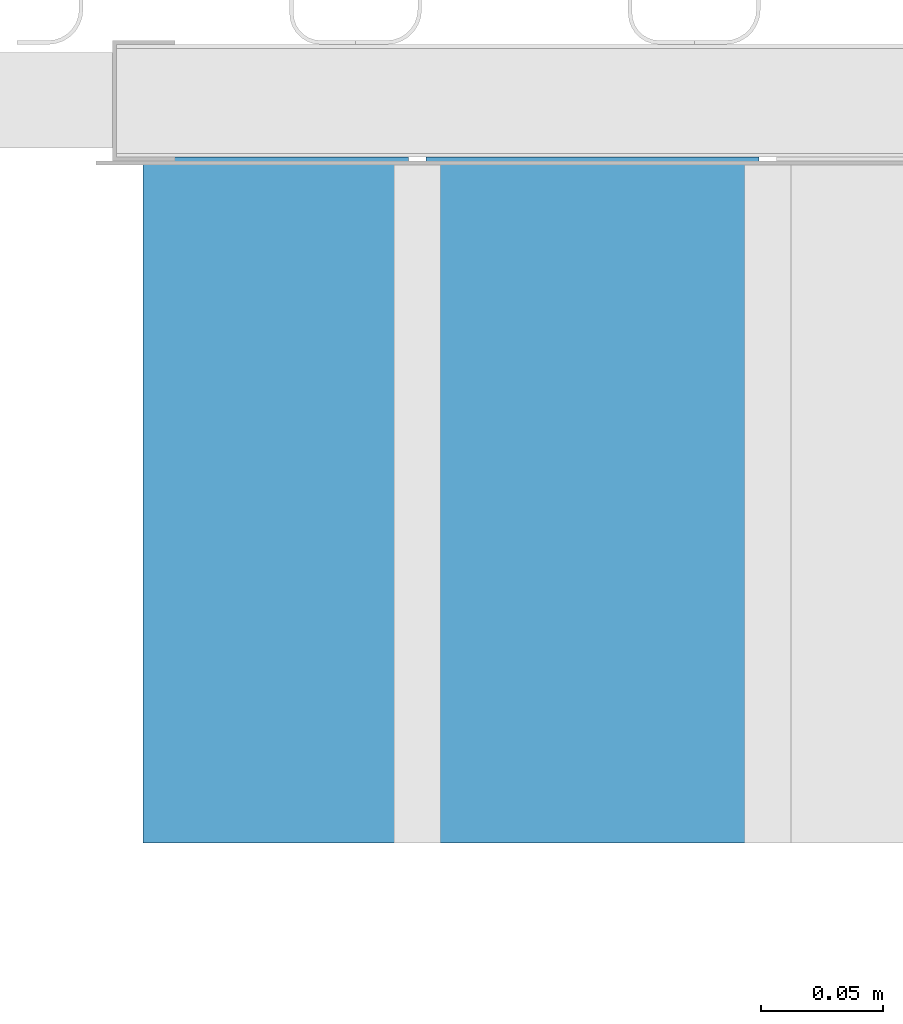
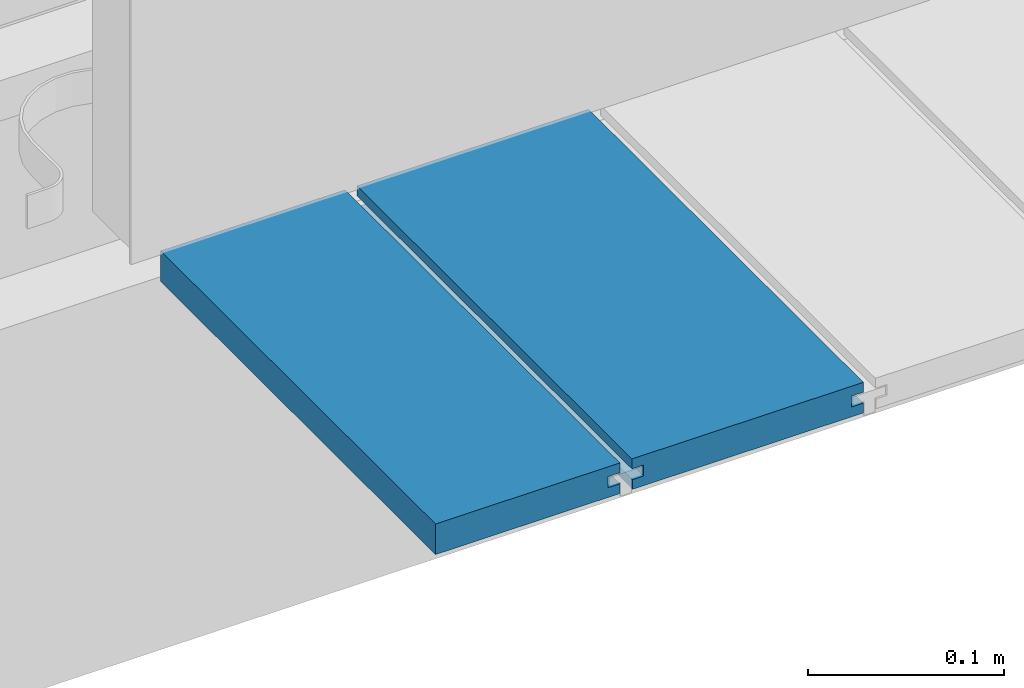
# One storey, part 16 of 33: 2 walls.
"""IFC4 building model written with IfcOpenShell, lengths in feet."""

from ifc_helpers import new_model, entity, si_unit, converted_unit, derived_unit, direction, frame, origin, place, context, subcontext, project, spatial, material, type_object, element, save


model = new_model("IFC4")

# Units and contexts
model_context = context("Model", 3, precision=0.0001, world=origin(), true_north=direction((6.12303176911189e-17, 1.0)))
body_context = subcontext(model_context, "Body", "Model", "MODEL_VIEW")
ifc_project = project(units=[converted_unit("LENGTHUNIT", "FOOT", entity("IfcRatioMeasure", 0.3048), si_unit("LENGTHUNIT", "METRE"), dimensions=[1, 0, 0, 0, 0, 0, 0]), converted_unit("AREAUNIT", "SQUARE FOOT", entity("IfcRatioMeasure", 0.09290304), si_unit("AREAUNIT", "SQUARE_METRE"), dimensions=[2, 0, 0, 0, 0, 0, 0]), converted_unit("VOLUMEUNIT", "CUBIC FOOT", entity("IfcRatioMeasure", 0.028316846592), si_unit("VOLUMEUNIT", "CUBIC_METRE"), dimensions=[3, 0, 0, 0, 0, 0, 0]), converted_unit("PLANEANGLEUNIT", "DEGREE", entity("IfcRatioMeasure", 0.0174532925199433), si_unit("PLANEANGLEUNIT", "RADIAN"), dimensions=[0, 0, 0, 0, 0, 0, 0]), si_unit("MASSUNIT", "GRAM", prefix="KILO"), derived_unit("MASSDENSITYUNIT", [(si_unit("MASSUNIT", "GRAM", prefix="KILO"), 1), (si_unit("LENGTHUNIT", "METRE"), -3)]), derived_unit("MOMENTOFINERTIAUNIT", [(si_unit("LENGTHUNIT", "METRE"), 4)]), si_unit("TIMEUNIT", "SECOND"), si_unit("FREQUENCYUNIT", "HERTZ"), si_unit("THERMODYNAMICTEMPERATUREUNIT", "DEGREE_CELSIUS"), derived_unit("THERMALTRANSMITTANCEUNIT", [(si_unit("MASSUNIT", "GRAM", prefix="KILO"), 1), (si_unit("THERMODYNAMICTEMPERATUREUNIT", "KELVIN"), -1), (si_unit("TIMEUNIT", "SECOND"), -3)]), derived_unit("VOLUMETRICFLOWRATEUNIT", [(si_unit("LENGTHUNIT", "METRE"), 3), (si_unit("TIMEUNIT", "SECOND"), -1)]), si_unit("ELECTRICCURRENTUNIT", "AMPERE"), si_unit("ELECTRICVOLTAGEUNIT", "VOLT"), si_unit("POWERUNIT", "WATT"), si_unit("FORCEUNIT", "NEWTON"), si_unit("ILLUMINANCEUNIT", "LUX"), si_unit("LUMINOUSFLUXUNIT", "LUMEN"), si_unit("LUMINOUSINTENSITYUNIT", "CANDELA"), derived_unit("USERDEFINED", [(si_unit("MASSUNIT", "GRAM", prefix="KILO"), -1), (si_unit("LENGTHUNIT", "METRE"), -2), (si_unit("TIMEUNIT", "SECOND"), 3), (si_unit("LUMINOUSFLUXUNIT", "LUMEN"), 1)]), derived_unit("LINEARVELOCITYUNIT", [(si_unit("LENGTHUNIT", "METRE"), 1), (si_unit("TIMEUNIT", "SECOND"), -1)]), si_unit("PRESSUREUNIT", "PASCAL"), derived_unit("USERDEFINED", [(si_unit("LENGTHUNIT", "METRE"), -2), (si_unit("MASSUNIT", "GRAM", prefix="KILO"), 1), (si_unit("TIMEUNIT", "SECOND"), -2)]), derived_unit("LINEARFORCEUNIT", [(si_unit("MASSUNIT", "GRAM", prefix="KILO"), 1), (si_unit("LENGTHUNIT", "METRE"), 1), (si_unit("TIMEUNIT", "SECOND"), -2), (si_unit("LENGTHUNIT", "METRE"), -1)]), derived_unit("PLANARFORCEUNIT", [(si_unit("MASSUNIT", "GRAM", prefix="KILO"), 1), (si_unit("LENGTHUNIT", "METRE"), 1), (si_unit("TIMEUNIT", "SECOND"), -2), (si_unit("LENGTHUNIT", "METRE"), -2)])], contexts=[model_context])

# Site, building, storey
site_placement = place(None, origin())
site = spatial("IfcSite", under=ifc_project, at=site_placement, CompositionType="ELEMENT")
building_placement = place(site_placement, origin())
building = spatial("IfcBuilding", under=site, at=building_placement, CompositionType="ELEMENT")
storey_placement = place(building_placement, frame((0.0, 0.0, 10.0)))
storey = spatial("IfcBuildingStorey", under=building, at=storey_placement, Name="2ND FLOOR", CompositionType="ELEMENT", Elevation=10.0000000000002)

# Walls
ifc_material = material(Name="COMPOSITE DECKING W/ HIDDEN FASTENERS", Category="Materials")
wall_type_1 = type_object("IfcWallType", Name="Generic Models 735:Generic Models 1", PredefinedType="NOTDEFINED", material=ifc_material)
wall_1_placement = place(storey_placement, frame((1487.77329242771, 3.04611392999271, 0.682902157150151), z_axis=(0.0, 0.0, 1.0), x_axis=(0.0, 1.0, 0.0)))
cartesian_point_1 = entity("IfcCartesianPoint", [0.919003339851617, -0.446740923891412, 0.0])
vertex_point_1 = entity("IfcVertexPoint", cartesian_point_1)
cartesian_point_2 = entity("IfcCartesianPoint", [0.919003339851619, -0.00132475379450625, 0.0])
vertex_point_2 = entity("IfcVertexPoint", cartesian_point_2)
ifc_direction_1 = entity("IfcDirection", [0.0, 1.0, 0.0])
edge_curve_1 = entity("IfcEdgeCurve", vertex_point_1, vertex_point_2, entity("IfcTrimmedCurve", entity("IfcLine", cartesian_point_1, entity("IfcVector", ifc_direction_1, 1.0)), [cartesian_point_1], [cartesian_point_2], True, "CARTESIAN"), True)
cartesian_point_3 = entity("IfcCartesianPoint", [0.919003339851619, -0.00132475379450625, 0.0198779960861479])
vertex_point_3 = entity("IfcVertexPoint", cartesian_point_3)
ifc_direction_2 = entity("IfcDirection", [0.0, 0.0, 1.0])
edge_curve_2 = entity("IfcEdgeCurve", vertex_point_2, vertex_point_3, entity("IfcTrimmedCurve", entity("IfcLine", cartesian_point_2, entity("IfcVector", ifc_direction_2, 1.0)), [cartesian_point_2], [cartesian_point_3], True, "CARTESIAN"), True)
cartesian_point_4 = entity("IfcCartesianPoint", [0.919003339851619, -0.0228400010807945, 0.0198779960861462])
vertex_point_4 = entity("IfcVertexPoint", cartesian_point_4)
ifc_direction_3 = entity("IfcDirection", [0.0, -1.0, 0.0])
edge_curve_3 = entity("IfcEdgeCurve", vertex_point_3, vertex_point_4, entity("IfcTrimmedCurve", entity("IfcLine", cartesian_point_3, entity("IfcVector", ifc_direction_3, 1.0)), [cartesian_point_3], [cartesian_point_4], True, "CARTESIAN"), True)
cartesian_point_5 = entity("IfcCartesianPoint", [0.919003339851619, -0.0228400010807945, 0.0422987663426504])
vertex_point_5 = entity("IfcVertexPoint", cartesian_point_5)
edge_curve_4 = entity("IfcEdgeCurve", vertex_point_4, vertex_point_5, entity("IfcTrimmedCurve", entity("IfcLine", cartesian_point_4, entity("IfcVector", ifc_direction_2, 1.0)), [cartesian_point_4], [cartesian_point_5], True, "CARTESIAN"), True)
cartesian_point_6 = entity("IfcCartesianPoint", [0.919003339851619, 0.0, 0.0422987663426522])
vertex_point_6 = entity("IfcVertexPoint", cartesian_point_6)
edge_curve_5 = entity("IfcEdgeCurve", vertex_point_5, vertex_point_6, entity("IfcTrimmedCurve", entity("IfcLine", cartesian_point_5, entity("IfcVector", ifc_direction_1, 1.0)), [cartesian_point_5], [cartesian_point_6], True, "CARTESIAN"), True)
cartesian_point_7 = entity("IfcCartesianPoint", [0.919003339851619, 0.0, 0.0625000000000551])
vertex_point_7 = entity("IfcVertexPoint", cartesian_point_7)
edge_curve_6 = entity("IfcEdgeCurve", vertex_point_6, vertex_point_7, entity("IfcTrimmedCurve", entity("IfcLine", cartesian_point_6, entity("IfcVector", ifc_direction_2, 1.0)), [cartesian_point_6], [cartesian_point_7], True, "CARTESIAN"), True)
cartesian_point_8 = entity("IfcCartesianPoint", [0.919003339851617, -0.446740923891639, 0.0624999999999982])
vertex_point_8 = entity("IfcVertexPoint", cartesian_point_8)
edge_curve_7 = entity("IfcEdgeCurve", vertex_point_7, vertex_point_8, entity("IfcTrimmedCurve", entity("IfcLine", cartesian_point_7, entity("IfcVector", ifc_direction_3, 1.0)), [cartesian_point_7], [cartesian_point_8], True, "CARTESIAN"), True)
cartesian_point_9 = entity("IfcCartesianPoint", [0.919003339851617, -0.446740923891639, 0.0422987663426522])
vertex_point_9 = entity("IfcVertexPoint", cartesian_point_9)
ifc_direction_4 = entity("IfcDirection", [0.0, 0.0, -1.0])
edge_curve_8 = entity("IfcEdgeCurve", vertex_point_8, vertex_point_9, entity("IfcTrimmedCurve", entity("IfcLine", cartesian_point_8, entity("IfcVector", ifc_direction_4, 1.0)), [cartesian_point_8], [cartesian_point_9], True, "CARTESIAN"), True)
cartesian_point_10 = entity("IfcCartesianPoint", [0.919003339851617, -0.423900922810617, 0.0422987663426504])
vertex_point_10 = entity("IfcVertexPoint", cartesian_point_10)
edge_curve_9 = entity("IfcEdgeCurve", vertex_point_9, vertex_point_10, entity("IfcTrimmedCurve", entity("IfcLine", cartesian_point_9, entity("IfcVector", ifc_direction_1, 1.0)), [cartesian_point_9], [cartesian_point_10], True, "CARTESIAN"), True)
cartesian_point_11 = entity("IfcCartesianPoint", [0.919003339851617, -0.423900922810617, 0.0198779960861462])
vertex_point_11 = entity("IfcVertexPoint", cartesian_point_11)
edge_curve_10 = entity("IfcEdgeCurve", vertex_point_10, vertex_point_11, entity("IfcTrimmedCurve", entity("IfcLine", cartesian_point_10, entity("IfcVector", ifc_direction_4, 1.0)), [cartesian_point_10], [cartesian_point_11], True, "CARTESIAN"), True)
cartesian_point_12 = entity("IfcCartesianPoint", [0.919003339851617, -0.446740923891412, 0.0198779960861479])
vertex_point_12 = entity("IfcVertexPoint", cartesian_point_12)
edge_curve_11 = entity("IfcEdgeCurve", vertex_point_11, vertex_point_12, entity("IfcTrimmedCurve", entity("IfcLine", cartesian_point_11, entity("IfcVector", ifc_direction_3, 1.0)), [cartesian_point_11], [cartesian_point_12], True, "CARTESIAN"), True)
edge_curve_12 = entity("IfcEdgeCurve", vertex_point_12, vertex_point_1, entity("IfcTrimmedCurve", entity("IfcLine", cartesian_point_12, entity("IfcVector", ifc_direction_4, 1.0)), [cartesian_point_12], [cartesian_point_1], True, "CARTESIAN"), True)
ifc_direction_5 = entity("IfcDirection", [1.0, 0.0, 0.0])
cartesian_point_13 = entity("IfcCartesianPoint", [0.0, -0.446740923891412, 0.0])
vertex_point_13 = entity("IfcVertexPoint", cartesian_point_13)
cartesian_point_14 = entity("IfcCartesianPoint", [0.0, -0.446740923891412, 0.0198779960861479])
vertex_point_14 = entity("IfcVertexPoint", cartesian_point_14)
edge_curve_13 = entity("IfcEdgeCurve", vertex_point_13, vertex_point_14, entity("IfcTrimmedCurve", entity("IfcLine", cartesian_point_13, entity("IfcVector", ifc_direction_2, 1.0)), [cartesian_point_13], [cartesian_point_14], True, "CARTESIAN"), True)
cartesian_point_15 = entity("IfcCartesianPoint", [0.0, -0.423900922810617, 0.0198779960861462])
vertex_point_15 = entity("IfcVertexPoint", cartesian_point_15)
edge_curve_14 = entity("IfcEdgeCurve", vertex_point_14, vertex_point_15, entity("IfcTrimmedCurve", entity("IfcLine", cartesian_point_14, entity("IfcVector", ifc_direction_1, 1.0)), [cartesian_point_14], [cartesian_point_15], True, "CARTESIAN"), True)
cartesian_point_16 = entity("IfcCartesianPoint", [0.0, -0.423900922810617, 0.0422987663426504])
vertex_point_16 = entity("IfcVertexPoint", cartesian_point_16)
edge_curve_15 = entity("IfcEdgeCurve", vertex_point_15, vertex_point_16, entity("IfcTrimmedCurve", entity("IfcLine", cartesian_point_15, entity("IfcVector", ifc_direction_2, 1.0)), [cartesian_point_15], [cartesian_point_16], True, "CARTESIAN"), True)
cartesian_point_17 = entity("IfcCartesianPoint", [0.0, -0.446740923891639, 0.0422987663426522])
vertex_point_17 = entity("IfcVertexPoint", cartesian_point_17)
edge_curve_16 = entity("IfcEdgeCurve", vertex_point_16, vertex_point_17, entity("IfcTrimmedCurve", entity("IfcLine", cartesian_point_16, entity("IfcVector", ifc_direction_3, 1.0)), [cartesian_point_16], [cartesian_point_17], True, "CARTESIAN"), True)
cartesian_point_18 = entity("IfcCartesianPoint", [0.0, -0.446740923891639, 0.0624999999999982])
vertex_point_18 = entity("IfcVertexPoint", cartesian_point_18)
edge_curve_17 = entity("IfcEdgeCurve", vertex_point_17, vertex_point_18, entity("IfcTrimmedCurve", entity("IfcLine", cartesian_point_17, entity("IfcVector", ifc_direction_2, 1.0)), [cartesian_point_17], [cartesian_point_18], True, "CARTESIAN"), True)
cartesian_point_19 = entity("IfcCartesianPoint", [0.0, 0.0, 0.0625000000000551])
vertex_point_19 = entity("IfcVertexPoint", cartesian_point_19)
edge_curve_18 = entity("IfcEdgeCurve", vertex_point_18, vertex_point_19, entity("IfcTrimmedCurve", entity("IfcLine", cartesian_point_18, entity("IfcVector", ifc_direction_1, 1.0)), [cartesian_point_18], [cartesian_point_19], True, "CARTESIAN"), True)
cartesian_point_20 = entity("IfcCartesianPoint", [0.0, 0.0, 0.0422987663426522])
vertex_point_20 = entity("IfcVertexPoint", cartesian_point_20)
edge_curve_19 = entity("IfcEdgeCurve", vertex_point_19, vertex_point_20, entity("IfcTrimmedCurve", entity("IfcLine", cartesian_point_19, entity("IfcVector", ifc_direction_4, 1.0)), [cartesian_point_19], [cartesian_point_20], True, "CARTESIAN"), True)
cartesian_point_21 = entity("IfcCartesianPoint", [0.0, -0.0228400010807945, 0.0422987663426504])
vertex_point_21 = entity("IfcVertexPoint", cartesian_point_21)
edge_curve_20 = entity("IfcEdgeCurve", vertex_point_20, vertex_point_21, entity("IfcTrimmedCurve", entity("IfcLine", cartesian_point_20, entity("IfcVector", ifc_direction_3, 1.0)), [cartesian_point_20], [cartesian_point_21], True, "CARTESIAN"), True)
cartesian_point_22 = entity("IfcCartesianPoint", [0.0, -0.0228400010807945, 0.0198779960861462])
vertex_point_22 = entity("IfcVertexPoint", cartesian_point_22)
edge_curve_21 = entity("IfcEdgeCurve", vertex_point_21, vertex_point_22, entity("IfcTrimmedCurve", entity("IfcLine", cartesian_point_21, entity("IfcVector", ifc_direction_4, 1.0)), [cartesian_point_21], [cartesian_point_22], True, "CARTESIAN"), True)
cartesian_point_23 = entity("IfcCartesianPoint", [0.0, -0.00132475379450625, 0.0198779960861479])
vertex_point_23 = entity("IfcVertexPoint", cartesian_point_23)
edge_curve_22 = entity("IfcEdgeCurve", vertex_point_22, vertex_point_23, entity("IfcTrimmedCurve", entity("IfcLine", cartesian_point_22, entity("IfcVector", ifc_direction_1, 1.0)), [cartesian_point_22], [cartesian_point_23], True, "CARTESIAN"), True)
cartesian_point_24 = entity("IfcCartesianPoint", [0.0, -0.00132475379450625, 0.0])
vertex_point_24 = entity("IfcVertexPoint", cartesian_point_24)
edge_curve_23 = entity("IfcEdgeCurve", vertex_point_23, vertex_point_24, entity("IfcTrimmedCurve", entity("IfcLine", cartesian_point_23, entity("IfcVector", ifc_direction_4, 1.0)), [cartesian_point_23], [cartesian_point_24], True, "CARTESIAN"), True)
edge_curve_24 = entity("IfcEdgeCurve", vertex_point_24, vertex_point_13, entity("IfcTrimmedCurve", entity("IfcLine", cartesian_point_24, entity("IfcVector", ifc_direction_3, 1.0)), [cartesian_point_24], [cartesian_point_13], True, "CARTESIAN"), True)
ifc_direction_6 = entity("IfcDirection", [-1.0, 0.0, 0.0])
edge_curve_25 = entity("IfcEdgeCurve", vertex_point_13, vertex_point_1, entity("IfcTrimmedCurve", entity("IfcLine", cartesian_point_13, entity("IfcVector", ifc_direction_5, 1.0)), [cartesian_point_13], [cartesian_point_1], True, "CARTESIAN"), True)
edge_curve_26 = entity("IfcEdgeCurve", vertex_point_12, vertex_point_14, entity("IfcTrimmedCurve", entity("IfcLine", cartesian_point_14, entity("IfcVector", ifc_direction_6, 1.0)), [cartesian_point_12], [cartesian_point_14], True, "CARTESIAN"), True)
edge_curve_27 = entity("IfcEdgeCurve", vertex_point_18, vertex_point_8, entity("IfcTrimmedCurve", entity("IfcLine", cartesian_point_18, entity("IfcVector", ifc_direction_5, 1.0)), [cartesian_point_18], [cartesian_point_8], True, "CARTESIAN"), True)
edge_curve_28 = entity("IfcEdgeCurve", vertex_point_7, vertex_point_19, entity("IfcTrimmedCurve", entity("IfcLine", cartesian_point_19, entity("IfcVector", ifc_direction_6, 1.0)), [cartesian_point_7], [cartesian_point_19], True, "CARTESIAN"), True)
edge_curve_29 = entity("IfcEdgeCurve", vertex_point_6, vertex_point_20, entity("IfcTrimmedCurve", entity("IfcLine", cartesian_point_20, entity("IfcVector", ifc_direction_6, 1.0)), [cartesian_point_6], [cartesian_point_20], True, "CARTESIAN"), True)
edge_curve_30 = entity("IfcEdgeCurve", vertex_point_24, vertex_point_2, entity("IfcTrimmedCurve", entity("IfcLine", cartesian_point_24, entity("IfcVector", ifc_direction_5, 1.0)), [cartesian_point_24], [cartesian_point_2], True, "CARTESIAN"), True)
edge_curve_31 = entity("IfcEdgeCurve", vertex_point_17, vertex_point_9, entity("IfcTrimmedCurve", entity("IfcLine", cartesian_point_17, entity("IfcVector", ifc_direction_5, 1.0)), [cartesian_point_17], [cartesian_point_9], True, "CARTESIAN"), True)
edge_curve_32 = entity("IfcEdgeCurve", vertex_point_5, vertex_point_21, entity("IfcTrimmedCurve", entity("IfcLine", cartesian_point_21, entity("IfcVector", ifc_direction_6, 1.0)), [cartesian_point_5], [cartesian_point_21], True, "CARTESIAN"), True)
edge_curve_33 = entity("IfcEdgeCurve", vertex_point_4, vertex_point_22, entity("IfcTrimmedCurve", entity("IfcLine", cartesian_point_22, entity("IfcVector", ifc_direction_6, 1.0)), [cartesian_point_4], [cartesian_point_22], True, "CARTESIAN"), True)
edge_curve_34 = entity("IfcEdgeCurve", vertex_point_3, vertex_point_23, entity("IfcTrimmedCurve", entity("IfcLine", cartesian_point_23, entity("IfcVector", ifc_direction_6, 1.0)), [cartesian_point_3], [cartesian_point_23], True, "CARTESIAN"), True)
edge_curve_35 = entity("IfcEdgeCurve", vertex_point_11, vertex_point_15, entity("IfcTrimmedCurve", entity("IfcLine", cartesian_point_15, entity("IfcVector", ifc_direction_6, 1.0)), [cartesian_point_11], [cartesian_point_15], True, "CARTESIAN"), True)
edge_curve_36 = entity("IfcEdgeCurve", vertex_point_10, vertex_point_16, entity("IfcTrimmedCurve", entity("IfcLine", cartesian_point_16, entity("IfcVector", ifc_direction_6, 1.0)), [cartesian_point_10], [cartesian_point_16], True, "CARTESIAN"), True)
element("IfcWall", 1, at=wall_1_placement, inside=storey, type_object=wall_type_1, material=ifc_material, Name="Generic Models 735:Generic Models 1", ObjectType="Generic Models 735:Generic Models 1", PredefinedType="NOTDEFINED", context=body_context, shape_type="AdvancedBrep", body=[
    entity("IfcAdvancedBrep", entity("IfcClosedShell", [entity("IfcAdvancedFace", [entity("IfcFaceOuterBound", entity("IfcEdgeLoop", [entity("IfcOrientedEdge", None, None, edge_curve_1, True), entity("IfcOrientedEdge", None, None, edge_curve_2, True), entity("IfcOrientedEdge", None, None, edge_curve_3, True), entity("IfcOrientedEdge", None, None, edge_curve_4, True), entity("IfcOrientedEdge", None, None, edge_curve_5, True), entity("IfcOrientedEdge", None, None, edge_curve_6, True), entity("IfcOrientedEdge", None, None, edge_curve_7, True), entity("IfcOrientedEdge", None, None, edge_curve_8, True), entity("IfcOrientedEdge", None, None, edge_curve_9, True), entity("IfcOrientedEdge", None, None, edge_curve_10, True), entity("IfcOrientedEdge", None, None, edge_curve_11, True), entity("IfcOrientedEdge", None, None, edge_curve_12, True)]), True)], entity("IfcPlane", entity("IfcAxis2Placement3D", entity("IfcCartesianPoint", [0.919003339851617, -0.446740923891412, -0.0208333333328241]), ifc_direction_5, ifc_direction_4)), True), entity("IfcAdvancedFace", [entity("IfcFaceOuterBound", entity("IfcEdgeLoop", [entity("IfcOrientedEdge", None, None, edge_curve_13, True), entity("IfcOrientedEdge", None, None, edge_curve_14, True), entity("IfcOrientedEdge", None, None, edge_curve_15, True), entity("IfcOrientedEdge", None, None, edge_curve_16, True), entity("IfcOrientedEdge", None, None, edge_curve_17, True), entity("IfcOrientedEdge", None, None, edge_curve_18, True), entity("IfcOrientedEdge", None, None, edge_curve_19, True), entity("IfcOrientedEdge", None, None, edge_curve_20, True), entity("IfcOrientedEdge", None, None, edge_curve_21, True), entity("IfcOrientedEdge", None, None, edge_curve_22, True), entity("IfcOrientedEdge", None, None, edge_curve_23, True), entity("IfcOrientedEdge", None, None, edge_curve_24, True)]), True)], entity("IfcPlane", entity("IfcAxis2Placement3D", entity("IfcCartesianPoint", [0.0, -0.446740923891412, -0.0208333333328241]), ifc_direction_6, ifc_direction_2)), True), entity("IfcAdvancedFace", [entity("IfcFaceOuterBound", entity("IfcEdgeLoop", [entity("IfcOrientedEdge", None, None, edge_curve_13, False), entity("IfcOrientedEdge", None, None, edge_curve_25, True), entity("IfcOrientedEdge", None, None, edge_curve_12, False), entity("IfcOrientedEdge", None, None, edge_curve_26, True)]), True)], entity("IfcPlane", entity("IfcAxis2Placement3D", cartesian_point_13, ifc_direction_3, ifc_direction_5)), True), entity("IfcAdvancedFace", [entity("IfcFaceOuterBound", entity("IfcEdgeLoop", [entity("IfcOrientedEdge", None, None, edge_curve_18, False), entity("IfcOrientedEdge", None, None, edge_curve_27, True), entity("IfcOrientedEdge", None, None, edge_curve_7, False), entity("IfcOrientedEdge", None, None, edge_curve_28, True)]), True)], entity("IfcPlane", entity("IfcAxis2Placement3D", cartesian_point_18, ifc_direction_2, ifc_direction_5)), True), entity("IfcAdvancedFace", [entity("IfcFaceOuterBound", entity("IfcEdgeLoop", [entity("IfcOrientedEdge", None, None, edge_curve_19, False), entity("IfcOrientedEdge", None, None, edge_curve_28, False), entity("IfcOrientedEdge", None, None, edge_curve_6, False), entity("IfcOrientedEdge", None, None, edge_curve_29, True)]), True)], entity("IfcPlane", entity("IfcAxis2Placement3D", cartesian_point_19, ifc_direction_1, ifc_direction_5)), True), entity("IfcAdvancedFace", [entity("IfcFaceOuterBound", entity("IfcEdgeLoop", [entity("IfcOrientedEdge", None, None, edge_curve_24, False), entity("IfcOrientedEdge", None, None, edge_curve_30, True), entity("IfcOrientedEdge", None, None, edge_curve_1, False), entity("IfcOrientedEdge", None, None, edge_curve_25, False)]), True)], entity("IfcPlane", entity("IfcAxis2Placement3D", cartesian_point_24, ifc_direction_4, ifc_direction_5)), True), entity("IfcAdvancedFace", [entity("IfcFaceOuterBound", entity("IfcEdgeLoop", [entity("IfcOrientedEdge", None, None, edge_curve_17, False), entity("IfcOrientedEdge", None, None, edge_curve_31, True), entity("IfcOrientedEdge", None, None, edge_curve_8, False), entity("IfcOrientedEdge", None, None, edge_curve_27, False)]), True)], entity("IfcPlane", entity("IfcAxis2Placement3D", cartesian_point_17, ifc_direction_3, ifc_direction_5)), True), entity("IfcAdvancedFace", [entity("IfcFaceOuterBound", entity("IfcEdgeLoop", [entity("IfcOrientedEdge", None, None, edge_curve_20, False), entity("IfcOrientedEdge", None, None, edge_curve_29, False), entity("IfcOrientedEdge", None, None, edge_curve_5, False), entity("IfcOrientedEdge", None, None, edge_curve_32, True)]), True)], entity("IfcPlane", entity("IfcAxis2Placement3D", cartesian_point_20, ifc_direction_4, ifc_direction_5)), True), entity("IfcAdvancedFace", [entity("IfcFaceOuterBound", entity("IfcEdgeLoop", [entity("IfcOrientedEdge", None, None, edge_curve_21, False), entity("IfcOrientedEdge", None, None, edge_curve_32, False), entity("IfcOrientedEdge", None, None, edge_curve_4, False), entity("IfcOrientedEdge", None, None, edge_curve_33, True)]), True)], entity("IfcPlane", entity("IfcAxis2Placement3D", cartesian_point_21, ifc_direction_1, ifc_direction_5)), True), entity("IfcAdvancedFace", [entity("IfcFaceOuterBound", entity("IfcEdgeLoop", [entity("IfcOrientedEdge", None, None, edge_curve_22, False), entity("IfcOrientedEdge", None, None, edge_curve_33, False), entity("IfcOrientedEdge", None, None, edge_curve_3, False), entity("IfcOrientedEdge", None, None, edge_curve_34, True)]), True)], entity("IfcPlane", entity("IfcAxis2Placement3D", cartesian_point_22, ifc_direction_2, ifc_direction_5)), True), entity("IfcAdvancedFace", [entity("IfcFaceOuterBound", entity("IfcEdgeLoop", [entity("IfcOrientedEdge", None, None, edge_curve_23, False), entity("IfcOrientedEdge", None, None, edge_curve_34, False), entity("IfcOrientedEdge", None, None, edge_curve_2, False), entity("IfcOrientedEdge", None, None, edge_curve_30, False)]), True)], entity("IfcPlane", entity("IfcAxis2Placement3D", cartesian_point_23, ifc_direction_1, ifc_direction_5)), True), entity("IfcAdvancedFace", [entity("IfcFaceOuterBound", entity("IfcEdgeLoop", [entity("IfcOrientedEdge", None, None, edge_curve_14, False), entity("IfcOrientedEdge", None, None, edge_curve_26, False), entity("IfcOrientedEdge", None, None, edge_curve_11, False), entity("IfcOrientedEdge", None, None, edge_curve_35, True)]), True)], entity("IfcPlane", entity("IfcAxis2Placement3D", cartesian_point_14, ifc_direction_2, ifc_direction_5)), True), entity("IfcAdvancedFace", [entity("IfcFaceOuterBound", entity("IfcEdgeLoop", [entity("IfcOrientedEdge", None, None, edge_curve_15, False), entity("IfcOrientedEdge", None, None, edge_curve_35, False), entity("IfcOrientedEdge", None, None, edge_curve_10, False), entity("IfcOrientedEdge", None, None, edge_curve_36, True)]), True)], entity("IfcPlane", entity("IfcAxis2Placement3D", cartesian_point_15, ifc_direction_3, ifc_direction_5)), True), entity("IfcAdvancedFace", [entity("IfcFaceOuterBound", entity("IfcEdgeLoop", [entity("IfcOrientedEdge", None, None, edge_curve_16, False), entity("IfcOrientedEdge", None, None, edge_curve_36, False), entity("IfcOrientedEdge", None, None, edge_curve_9, False), entity("IfcOrientedEdge", None, None, edge_curve_31, False)]), True)], entity("IfcPlane", entity("IfcAxis2Placement3D", cartesian_point_16, ifc_direction_4, ifc_direction_5)), True)])),
])
wall_type_2 = type_object("IfcWallType", Name="Generic Models 736:Generic Models 1", PredefinedType="NOTDEFINED", material=ifc_material)
wall_2_placement = place(storey_placement, frame((1487.39448162332, 3.04611392999271, 0.682902157150153), z_axis=(0.0, 0.0, 1.0), x_axis=(0.0, 1.0, 0.0)))
cartesian_point_25 = entity("IfcCartesianPoint", [0.919003339851616, -0.355785426182592, 0.0])
vertex_point_25 = entity("IfcVertexPoint", cartesian_point_25)
cartesian_point_26 = entity("IfcCartesianPoint", [0.919003339851618, 0.0, 0.0])
vertex_point_26 = entity("IfcVertexPoint", cartesian_point_26)
ifc_direction_7 = entity("IfcDirection", [0.0, 1.0, 0.0])
edge_curve_37 = entity("IfcEdgeCurve", vertex_point_25, vertex_point_26, entity("IfcTrimmedCurve", entity("IfcLine", cartesian_point_25, entity("IfcVector", ifc_direction_7, 1.0)), [cartesian_point_25], [cartesian_point_26], True, "CARTESIAN"), True)
cartesian_point_27 = entity("IfcCartesianPoint", [0.919003339851618, 0.0, 0.0625000000000444])
vertex_point_27 = entity("IfcVertexPoint", cartesian_point_27)
ifc_direction_8 = entity("IfcDirection", [0.0, 0.0, 1.0])
edge_curve_38 = entity("IfcEdgeCurve", vertex_point_26, vertex_point_27, entity("IfcTrimmedCurve", entity("IfcLine", cartesian_point_26, entity("IfcVector", ifc_direction_8, 1.0)), [cartesian_point_26], [cartesian_point_27], True, "CARTESIAN"), True)
cartesian_point_28 = entity("IfcCartesianPoint", [0.919003339851616, -0.35578542618282, 0.0624999999999982])
vertex_point_28 = entity("IfcVertexPoint", cartesian_point_28)
ifc_direction_9 = entity("IfcDirection", [0.0, -1.0, 0.0])
edge_curve_39 = entity("IfcEdgeCurve", vertex_point_27, vertex_point_28, entity("IfcTrimmedCurve", entity("IfcLine", cartesian_point_27, entity("IfcVector", ifc_direction_9, 1.0)), [cartesian_point_27], [cartesian_point_28], True, "CARTESIAN"), True)
cartesian_point_29 = entity("IfcCartesianPoint", [0.919003339851616, -0.35578542618282, 0.0422987663426522])
vertex_point_29 = entity("IfcVertexPoint", cartesian_point_29)
ifc_direction_10 = entity("IfcDirection", [0.0, 0.0, -1.0])
edge_curve_40 = entity("IfcEdgeCurve", vertex_point_28, vertex_point_29, entity("IfcTrimmedCurve", entity("IfcLine", cartesian_point_28, entity("IfcVector", ifc_direction_10, 1.0)), [cartesian_point_28], [cartesian_point_29], True, "CARTESIAN"), True)
cartesian_point_30 = entity("IfcCartesianPoint", [0.919003339851616, -0.332945425101798, 0.0422987663426504])
vertex_point_30 = entity("IfcVertexPoint", cartesian_point_30)
edge_curve_41 = entity("IfcEdgeCurve", vertex_point_29, vertex_point_30, entity("IfcTrimmedCurve", entity("IfcLine", cartesian_point_29, entity("IfcVector", ifc_direction_7, 1.0)), [cartesian_point_29], [cartesian_point_30], True, "CARTESIAN"), True)
cartesian_point_31 = entity("IfcCartesianPoint", [0.919003339851616, -0.332945425101798, 0.0198779960861462])
vertex_point_31 = entity("IfcVertexPoint", cartesian_point_31)
edge_curve_42 = entity("IfcEdgeCurve", vertex_point_30, vertex_point_31, entity("IfcTrimmedCurve", entity("IfcLine", cartesian_point_30, entity("IfcVector", ifc_direction_10, 1.0)), [cartesian_point_30], [cartesian_point_31], True, "CARTESIAN"), True)
cartesian_point_32 = entity("IfcCartesianPoint", [0.919003339851616, -0.355785426182592, 0.0198779960861479])
vertex_point_32 = entity("IfcVertexPoint", cartesian_point_32)
edge_curve_43 = entity("IfcEdgeCurve", vertex_point_31, vertex_point_32, entity("IfcTrimmedCurve", entity("IfcLine", cartesian_point_31, entity("IfcVector", ifc_direction_9, 1.0)), [cartesian_point_31], [cartesian_point_32], True, "CARTESIAN"), True)
edge_curve_44 = entity("IfcEdgeCurve", vertex_point_32, vertex_point_25, entity("IfcTrimmedCurve", entity("IfcLine", cartesian_point_32, entity("IfcVector", ifc_direction_10, 1.0)), [cartesian_point_32], [cartesian_point_25], True, "CARTESIAN"), True)
ifc_direction_11 = entity("IfcDirection", [1.0, 0.0, 0.0])
cartesian_point_33 = entity("IfcCartesianPoint", [0.0, -0.355785426182592, 0.0])
vertex_point_33 = entity("IfcVertexPoint", cartesian_point_33)
cartesian_point_34 = entity("IfcCartesianPoint", [0.0, -0.355785426182592, 0.0198779960861479])
vertex_point_34 = entity("IfcVertexPoint", cartesian_point_34)
edge_curve_45 = entity("IfcEdgeCurve", vertex_point_33, vertex_point_34, entity("IfcTrimmedCurve", entity("IfcLine", cartesian_point_33, entity("IfcVector", ifc_direction_8, 1.0)), [cartesian_point_33], [cartesian_point_34], True, "CARTESIAN"), True)
cartesian_point_35 = entity("IfcCartesianPoint", [0.0, -0.332945425101798, 0.0198779960861462])
vertex_point_35 = entity("IfcVertexPoint", cartesian_point_35)
edge_curve_46 = entity("IfcEdgeCurve", vertex_point_34, vertex_point_35, entity("IfcTrimmedCurve", entity("IfcLine", cartesian_point_34, entity("IfcVector", ifc_direction_7, 1.0)), [cartesian_point_34], [cartesian_point_35], True, "CARTESIAN"), True)
cartesian_point_36 = entity("IfcCartesianPoint", [0.0, -0.332945425101798, 0.0422987663426504])
vertex_point_36 = entity("IfcVertexPoint", cartesian_point_36)
edge_curve_47 = entity("IfcEdgeCurve", vertex_point_35, vertex_point_36, entity("IfcTrimmedCurve", entity("IfcLine", cartesian_point_35, entity("IfcVector", ifc_direction_8, 1.0)), [cartesian_point_35], [cartesian_point_36], True, "CARTESIAN"), True)
cartesian_point_37 = entity("IfcCartesianPoint", [0.0, -0.35578542618282, 0.0422987663426522])
vertex_point_37 = entity("IfcVertexPoint", cartesian_point_37)
edge_curve_48 = entity("IfcEdgeCurve", vertex_point_36, vertex_point_37, entity("IfcTrimmedCurve", entity("IfcLine", cartesian_point_36, entity("IfcVector", ifc_direction_9, 1.0)), [cartesian_point_36], [cartesian_point_37], True, "CARTESIAN"), True)
cartesian_point_38 = entity("IfcCartesianPoint", [0.0, -0.35578542618282, 0.0624999999999982])
vertex_point_38 = entity("IfcVertexPoint", cartesian_point_38)
edge_curve_49 = entity("IfcEdgeCurve", vertex_point_37, vertex_point_38, entity("IfcTrimmedCurve", entity("IfcLine", cartesian_point_37, entity("IfcVector", ifc_direction_8, 1.0)), [cartesian_point_37], [cartesian_point_38], True, "CARTESIAN"), True)
cartesian_point_39 = entity("IfcCartesianPoint", [0.0, 0.0, 0.0625000000000444])
vertex_point_39 = entity("IfcVertexPoint", cartesian_point_39)
edge_curve_50 = entity("IfcEdgeCurve", vertex_point_38, vertex_point_39, entity("IfcTrimmedCurve", entity("IfcLine", cartesian_point_38, entity("IfcVector", ifc_direction_7, 1.0)), [cartesian_point_38], [cartesian_point_39], True, "CARTESIAN"), True)
cartesian_point_40 = entity("IfcCartesianPoint", [0.0, 0.0, 0.0])
vertex_point_40 = entity("IfcVertexPoint", cartesian_point_40)
edge_curve_51 = entity("IfcEdgeCurve", vertex_point_39, vertex_point_40, entity("IfcTrimmedCurve", entity("IfcLine", cartesian_point_39, entity("IfcVector", ifc_direction_10, 1.0)), [cartesian_point_39], [cartesian_point_40], True, "CARTESIAN"), True)
edge_curve_52 = entity("IfcEdgeCurve", vertex_point_40, vertex_point_33, entity("IfcTrimmedCurve", entity("IfcLine", cartesian_point_40, entity("IfcVector", ifc_direction_9, 1.0)), [cartesian_point_40], [cartesian_point_33], True, "CARTESIAN"), True)
ifc_direction_12 = entity("IfcDirection", [-1.0, 0.0, 0.0])
edge_curve_53 = entity("IfcEdgeCurve", vertex_point_33, vertex_point_25, entity("IfcTrimmedCurve", entity("IfcLine", cartesian_point_33, entity("IfcVector", ifc_direction_11, 1.0)), [cartesian_point_33], [cartesian_point_25], True, "CARTESIAN"), True)
edge_curve_54 = entity("IfcEdgeCurve", vertex_point_32, vertex_point_34, entity("IfcTrimmedCurve", entity("IfcLine", cartesian_point_34, entity("IfcVector", ifc_direction_12, 1.0)), [cartesian_point_32], [cartesian_point_34], True, "CARTESIAN"), True)
edge_curve_55 = entity("IfcEdgeCurve", vertex_point_38, vertex_point_28, entity("IfcTrimmedCurve", entity("IfcLine", cartesian_point_38, entity("IfcVector", ifc_direction_11, 1.0)), [cartesian_point_38], [cartesian_point_28], True, "CARTESIAN"), True)
edge_curve_56 = entity("IfcEdgeCurve", vertex_point_27, vertex_point_39, entity("IfcTrimmedCurve", entity("IfcLine", cartesian_point_39, entity("IfcVector", ifc_direction_12, 1.0)), [cartesian_point_27], [cartesian_point_39], True, "CARTESIAN"), True)
edge_curve_57 = entity("IfcEdgeCurve", vertex_point_40, vertex_point_26, entity("IfcTrimmedCurve", entity("IfcLine", cartesian_point_40, entity("IfcVector", ifc_direction_11, 1.0)), [cartesian_point_40], [cartesian_point_26], True, "CARTESIAN"), True)
edge_curve_58 = entity("IfcEdgeCurve", vertex_point_37, vertex_point_29, entity("IfcTrimmedCurve", entity("IfcLine", cartesian_point_37, entity("IfcVector", ifc_direction_11, 1.0)), [cartesian_point_37], [cartesian_point_29], True, "CARTESIAN"), True)
edge_curve_59 = entity("IfcEdgeCurve", vertex_point_31, vertex_point_35, entity("IfcTrimmedCurve", entity("IfcLine", cartesian_point_35, entity("IfcVector", ifc_direction_12, 1.0)), [cartesian_point_31], [cartesian_point_35], True, "CARTESIAN"), True)
edge_curve_60 = entity("IfcEdgeCurve", vertex_point_30, vertex_point_36, entity("IfcTrimmedCurve", entity("IfcLine", cartesian_point_36, entity("IfcVector", ifc_direction_12, 1.0)), [cartesian_point_30], [cartesian_point_36], True, "CARTESIAN"), True)
element("IfcWall", 2, at=wall_2_placement, inside=storey, type_object=wall_type_2, material=ifc_material, Name="Generic Models 736:Generic Models 1", ObjectType="Generic Models 736:Generic Models 1", PredefinedType="NOTDEFINED", context=body_context, shape_type="AdvancedBrep", body=[
    entity("IfcAdvancedBrep", entity("IfcClosedShell", [entity("IfcAdvancedFace", [entity("IfcFaceOuterBound", entity("IfcEdgeLoop", [entity("IfcOrientedEdge", None, None, edge_curve_37, True), entity("IfcOrientedEdge", None, None, edge_curve_38, True), entity("IfcOrientedEdge", None, None, edge_curve_39, True), entity("IfcOrientedEdge", None, None, edge_curve_40, True), entity("IfcOrientedEdge", None, None, edge_curve_41, True), entity("IfcOrientedEdge", None, None, edge_curve_42, True), entity("IfcOrientedEdge", None, None, edge_curve_43, True), entity("IfcOrientedEdge", None, None, edge_curve_44, True)]), True)], entity("IfcPlane", entity("IfcAxis2Placement3D", entity("IfcCartesianPoint", [0.919003339851616, -0.355785426182592, -0.0208333333328241]), ifc_direction_11, ifc_direction_10)), True), entity("IfcAdvancedFace", [entity("IfcFaceOuterBound", entity("IfcEdgeLoop", [entity("IfcOrientedEdge", None, None, edge_curve_45, True), entity("IfcOrientedEdge", None, None, edge_curve_46, True), entity("IfcOrientedEdge", None, None, edge_curve_47, True), entity("IfcOrientedEdge", None, None, edge_curve_48, True), entity("IfcOrientedEdge", None, None, edge_curve_49, True), entity("IfcOrientedEdge", None, None, edge_curve_50, True), entity("IfcOrientedEdge", None, None, edge_curve_51, True), entity("IfcOrientedEdge", None, None, edge_curve_52, True)]), True)], entity("IfcPlane", entity("IfcAxis2Placement3D", entity("IfcCartesianPoint", [0.0, -0.355785426182592, -0.0208333333328241]), ifc_direction_12, ifc_direction_8)), True), entity("IfcAdvancedFace", [entity("IfcFaceOuterBound", entity("IfcEdgeLoop", [entity("IfcOrientedEdge", None, None, edge_curve_45, False), entity("IfcOrientedEdge", None, None, edge_curve_53, True), entity("IfcOrientedEdge", None, None, edge_curve_44, False), entity("IfcOrientedEdge", None, None, edge_curve_54, True)]), True)], entity("IfcPlane", entity("IfcAxis2Placement3D", cartesian_point_33, ifc_direction_9, ifc_direction_11)), True), entity("IfcAdvancedFace", [entity("IfcFaceOuterBound", entity("IfcEdgeLoop", [entity("IfcOrientedEdge", None, None, edge_curve_50, False), entity("IfcOrientedEdge", None, None, edge_curve_55, True), entity("IfcOrientedEdge", None, None, edge_curve_39, False), entity("IfcOrientedEdge", None, None, edge_curve_56, True)]), True)], entity("IfcPlane", entity("IfcAxis2Placement3D", cartesian_point_38, ifc_direction_8, ifc_direction_11)), True), entity("IfcAdvancedFace", [entity("IfcFaceOuterBound", entity("IfcEdgeLoop", [entity("IfcOrientedEdge", None, None, edge_curve_52, False), entity("IfcOrientedEdge", None, None, edge_curve_57, True), entity("IfcOrientedEdge", None, None, edge_curve_37, False), entity("IfcOrientedEdge", None, None, edge_curve_53, False)]), True)], entity("IfcPlane", entity("IfcAxis2Placement3D", cartesian_point_40, ifc_direction_10, ifc_direction_11)), True), entity("IfcAdvancedFace", [entity("IfcFaceOuterBound", entity("IfcEdgeLoop", [entity("IfcOrientedEdge", None, None, edge_curve_49, False), entity("IfcOrientedEdge", None, None, edge_curve_58, True), entity("IfcOrientedEdge", None, None, edge_curve_40, False), entity("IfcOrientedEdge", None, None, edge_curve_55, False)]), True)], entity("IfcPlane", entity("IfcAxis2Placement3D", cartesian_point_37, ifc_direction_9, ifc_direction_11)), True), entity("IfcAdvancedFace", [entity("IfcFaceOuterBound", entity("IfcEdgeLoop", [entity("IfcOrientedEdge", None, None, edge_curve_46, False), entity("IfcOrientedEdge", None, None, edge_curve_54, False), entity("IfcOrientedEdge", None, None, edge_curve_43, False), entity("IfcOrientedEdge", None, None, edge_curve_59, True)]), True)], entity("IfcPlane", entity("IfcAxis2Placement3D", cartesian_point_34, ifc_direction_8, ifc_direction_11)), True), entity("IfcAdvancedFace", [entity("IfcFaceOuterBound", entity("IfcEdgeLoop", [entity("IfcOrientedEdge", None, None, edge_curve_47, False), entity("IfcOrientedEdge", None, None, edge_curve_59, False), entity("IfcOrientedEdge", None, None, edge_curve_42, False), entity("IfcOrientedEdge", None, None, edge_curve_60, True)]), True)], entity("IfcPlane", entity("IfcAxis2Placement3D", cartesian_point_35, ifc_direction_9, ifc_direction_11)), True), entity("IfcAdvancedFace", [entity("IfcFaceOuterBound", entity("IfcEdgeLoop", [entity("IfcOrientedEdge", None, None, edge_curve_48, False), entity("IfcOrientedEdge", None, None, edge_curve_60, False), entity("IfcOrientedEdge", None, None, edge_curve_41, False), entity("IfcOrientedEdge", None, None, edge_curve_58, False)]), True)], entity("IfcPlane", entity("IfcAxis2Placement3D", cartesian_point_36, ifc_direction_10, ifc_direction_11)), True), entity("IfcAdvancedFace", [entity("IfcFaceOuterBound", entity("IfcEdgeLoop", [entity("IfcOrientedEdge", None, None, edge_curve_51, False), entity("IfcOrientedEdge", None, None, edge_curve_56, False), entity("IfcOrientedEdge", None, None, edge_curve_38, False), entity("IfcOrientedEdge", None, None, edge_curve_57, False)]), True)], entity("IfcPlane", entity("IfcAxis2Placement3D", cartesian_point_39, ifc_direction_7, ifc_direction_11)), True)])),
])

save(model, "model.ifc")
